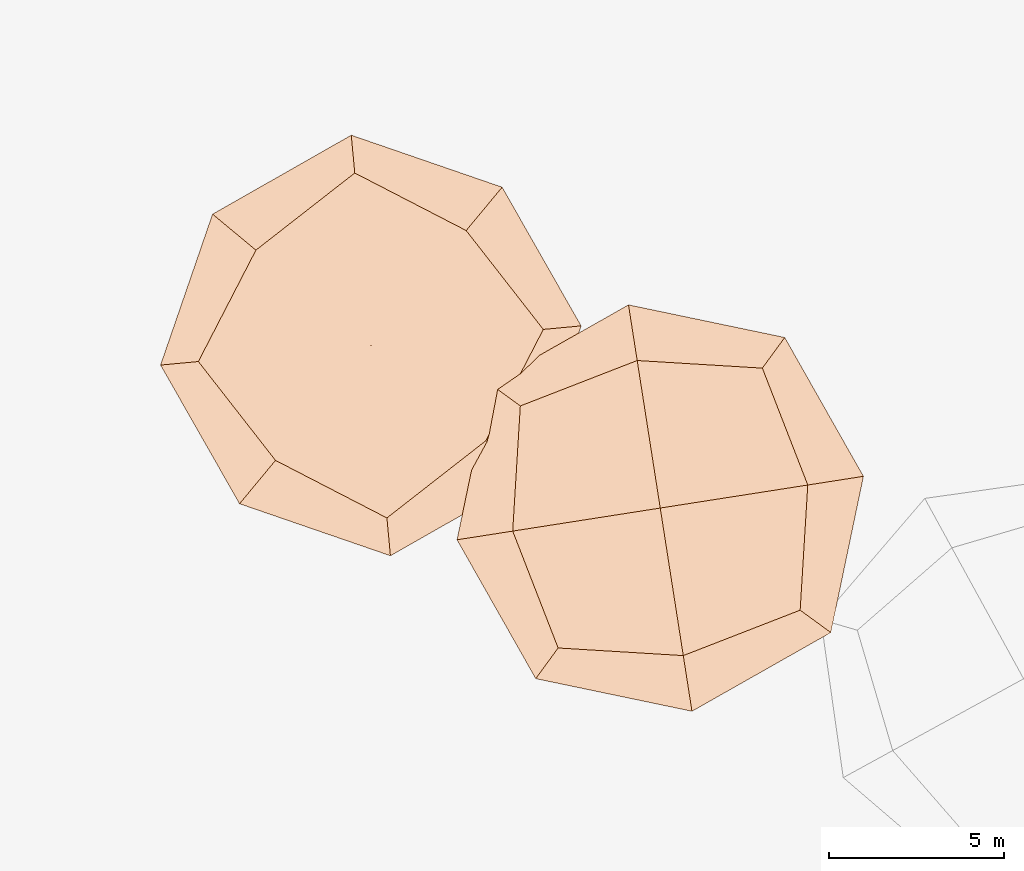
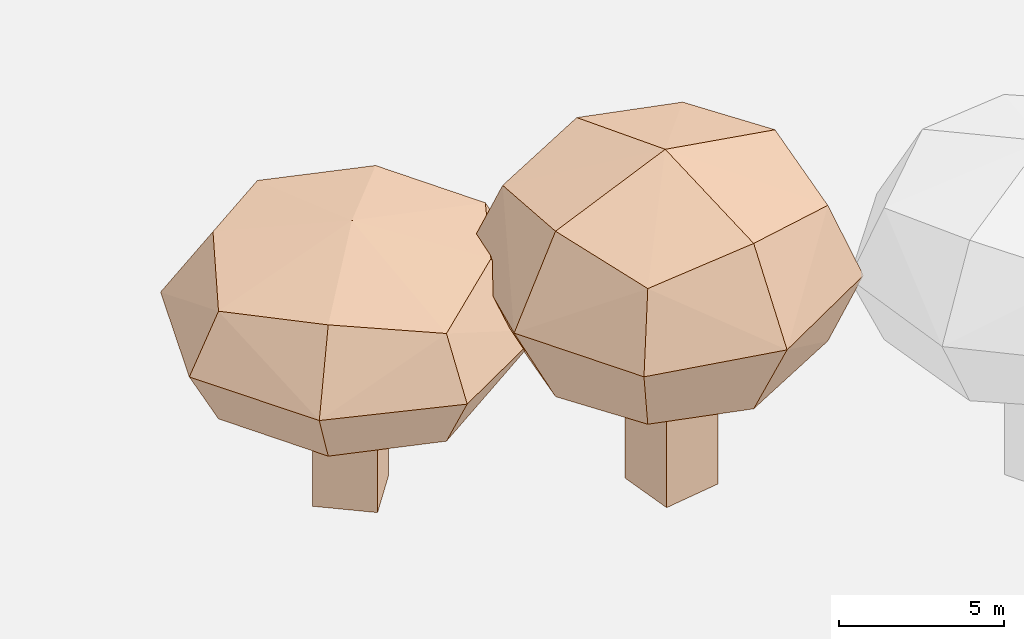
# Not in any storey, part 25 of 92: 2 geographic elements.
"""IFC4 model written with IfcOpenShell, lengths in metres."""

import ifcopenshell
import ifcopenshell.guid

model = None  # the IFC model being written
_history = None  # IfcOwnerHistory: only IFC2X3 demands one
_inside = {}  # id of a spatial element -> (the spatial element, [elements in it])
_under = {}  # id of a project, library or spatial element -> (it, [spatial elements below it])
_declared = {}  # id of a project -> (the project, [libraries it declares])
_typed = {}  # id of a type object -> (the type object, [elements of that type])
_made_of = {}  # id of a material, layer set ... -> (it, [elements and type objects made of it])


def new_model(schema):
    """Start an empty IFC model of exactly this schema.

    Asked for "IFC4X3", IfcOpenShell would pick the latest addendum, in which some entities
    have other attributes; the version numbers below select the first issue.
    IFC2X3 requires an IfcOwnerHistory on every rooted entity: one is made here for all.
    """
    global model, _history
    if schema == "IFC4X3":
        model = ifcopenshell.file(schema_version=(4, 3, 0, 0))
    else:
        model = ifcopenshell.file(schema=schema)
    _inside.clear()
    _under.clear()
    _declared.clear()
    _typed.clear()
    _made_of.clear()
    _history = None
    if model.schema == "IFC2X3":
        org = make("IfcOrganization", Name="unknown")
        user = make(
            "IfcPersonAndOrganization",
            ThePerson=make("IfcPerson", FamilyName="unknown"),
            TheOrganization=org,
        )
        app = make(
            "IfcApplication",
            ApplicationDeveloper=org,
            Version="unknown",
            ApplicationFullName="unknown",
            ApplicationIdentifier="unknown",
        )
        _history = make(
            "IfcOwnerHistory",
            OwningUser=user,
            OwningApplication=app,
            ChangeAction="ADDED",
            CreationDate=0,
        )
    return model


def make(cls, **values):
    """One entity of the class cls with the attributes given. An attribute that is None is left unset."""
    return model.create_entity(
        cls, **{name: value for name, value in values.items() if value is not None}
    )


def rooted(cls, **values):
    """An entity with a GlobalId (a new one), such as an element, a storey or a relation."""
    return make(cls, GlobalId=ifcopenshell.guid.new(), OwnerHistory=_history, **values)


def si_unit(unit_type, name, prefix=None):
    """IfcSIUnit, for example si_unit("LENGTHUNIT", "METRE", prefix="MILLI")."""
    return make("IfcSIUnit", UnitType=unit_type, Prefix=prefix, Name=name)


def assignment(units):
    """IfcUnitAssignment: the units of a project."""
    return None if units is None else make("IfcUnitAssignment", Units=units)


def point(xyz):
    """IfcCartesianPoint."""
    return None if xyz is None else make("IfcCartesianPoint", Coordinates=xyz)


def direction(xyz):
    """IfcDirection."""
    return None if xyz is None else make("IfcDirection", DirectionRatios=xyz)


def frame(location, z_axis=None, x_axis=None):
    """IfcAxis2Placement3D, a coordinate frame: its origin and axes. An axis left out is left unset."""
    return make(
        "IfcAxis2Placement3D",
        Location=point(location),
        Axis=direction(z_axis),
        RefDirection=direction(x_axis),
    )


def origin_with_axes():
    """The frame at (0, 0, 0) with the z axis (0, 0, 1) and the x axis (1, 0, 0) written out."""
    return frame((0.0, 0.0, 0.0), z_axis=(0.0, 0.0, 1.0), x_axis=(1.0, 0.0, 0.0))


def place(relative_to, where):
    """IfcLocalPlacement: puts the frame where relative to a parent placement (None: the world)."""
    return make(
        "IfcLocalPlacement", PlacementRelTo=relative_to, RelativePlacement=where
    )


def context(
    kind, dimensions, precision=None, world=None, true_north=None, identifier=None
):
    """IfcGeometricRepresentationContext, for example the 3D "Model" context."""
    return make(
        "IfcGeometricRepresentationContext",
        ContextIdentifier=identifier,
        ContextType=kind,
        CoordinateSpaceDimension=dimensions,
        Precision=precision,
        WorldCoordinateSystem=world,
        TrueNorth=true_north,
    )


def subcontext(parent, identifier, kind, view, scale=None):
    """IfcGeometricRepresentationSubContext, for example "Body" below "Model"."""
    return make(
        "IfcGeometricRepresentationSubContext",
        ContextIdentifier=identifier,
        ContextType=kind,
        ParentContext=parent,
        TargetScale=scale,
        TargetView=view,
    )


def project(units=None, contexts=None):
    """IfcProject with its units and contexts."""
    return rooted(
        "IfcProject",
        Name="project",
        RepresentationContexts=contexts,
        UnitsInContext=assignment(units),
    )


def spatial(cls, under=None, at=None, **own):
    """A site, building, storey or space (cls), placed at a placement, below another one or the project."""
    s = rooted(cls, ObjectPlacement=at, **own)
    if under is not None:
        _under.setdefault(under.id(), (under, []))[1].append(s)
    return s


def point_list(points):
    """IfcCartesianPointList2D or 3D."""
    cls = (
        "IfcCartesianPointList2D" if len(points[0]) == 2 else "IfcCartesianPointList3D"
    )
    return make(cls, CoordList=points)


def triangles(points, corners, closed=None, point_numbers=None):
    """IfcTriangulatedFaceSet: each triangle names its three corners, points numbered from 1."""
    return make(
        "IfcTriangulatedFaceSet",
        Coordinates=point_list(points),
        Closed=closed,
        CoordIndex=corners,
        PnIndex=point_numbers,
    )


def shape(context_of_items, identifier, shape_type, items):
    """IfcShapeRepresentation: the items that make up one representation, for example the "Body"."""
    return make(
        "IfcShapeRepresentation",
        ContextOfItems=context_of_items,
        RepresentationIdentifier=identifier,
        RepresentationType=shape_type,
        Items=items,
    )


def material(Name=None, Category=None):
    """IfcMaterial."""
    return make("IfcMaterial", Name=Name, Category=Category)


def made_of(thing, what):
    """Note that an element or type object is made of a material, layer set ...; save() writes the relation."""
    if what is not None:
        _made_of.setdefault(what.id(), (what, []))[1].append(thing)
    return thing


def element(
    cls,
    number,
    at=None,
    inside=None,
    cuts=None,
    type_object=None,
    material=None,
    context=None,
    identifier="Body",
    shape_type=None,
    held_by="IfcProductDefinitionShape",
    body=None,
    shapes=None,
    **own,
):
    """One element of the class cls, such as IfcWall. Its Tag is "e" and its number.

    at: its placement. inside: the storey or other place that contains it. cuts: it is an
    opening in that element (IfcRelVoidsElement). A single representation is given by context,
    identifier, shape_type and body (its items); several are given by shapes. held_by: the class
    of the entity that holds the representations. save() writes the other relations.
    """
    e = rooted(cls, Tag="e%d" % number, ObjectPlacement=at, **own)
    if body is not None:
        shapes = [shape(context, identifier, shape_type, body)]
    if shapes is not None:
        e.Representation = make(held_by, Representations=shapes)
    if inside is not None:
        _inside.setdefault(inside.id(), (inside, []))[1].append(e)
    if cuts is not None:
        rooted(
            "IfcRelVoidsElement", RelatingBuildingElement=cuts, RelatedOpeningElement=e
        )
    if type_object is not None:
        _typed.setdefault(type_object.id(), (type_object, []))[1].append(e)
    return made_of(e, material)


def aggregate(whole, parts):
    """IfcRelAggregates: a whole, such as a stair, and the parts it consists of."""
    return rooted("IfcRelAggregates", RelatingObject=whole, RelatedObjects=parts)


def save(model, path):
    """Write the relations noted so far, then the file.

    IfcRelAggregates (storeys below a building ...), IfcRelContainedInSpatialStructure (elements
    in a storey), IfcRelDefinesByType, IfcRelAssociatesMaterial and IfcRelDeclares: one each for
    every whole, place, type object, material and project.
    """
    for whole, parts in _under.values():
        aggregate(whole, parts)
    for where, things in _inside.values():
        rooted(
            "IfcRelContainedInSpatialStructure",
            RelatedElements=things,
            RelatingStructure=where,
        )
    for kind, things in _typed.values():
        rooted("IfcRelDefinesByType", RelatedObjects=things, RelatingType=kind)
    for what, things in _made_of.values():
        rooted("IfcRelAssociatesMaterial", RelatedObjects=things, RelatingMaterial=what)
    for by, libraries in _declared.values():
        rooted("IfcRelDeclares", RelatingContext=by, RelatedDefinitions=libraries)
    model.write(path)


model = new_model("IFC4")

# Units and contexts
model_context = context("Model", 3, precision=1e-05, world=origin_with_axes())
body_context = subcontext(model_context, "Body", "Model", "MODEL_VIEW")
ifc_project = project(units=[si_unit("VOLUMEUNIT", "CUBIC_METRE"), si_unit("LENGTHUNIT", "METRE"), si_unit("AREAUNIT", "SQUARE_METRE")], contexts=[model_context])

# Site
site_placement = place(None, origin_with_axes())
site = spatial("IfcSite", under=ifc_project, at=site_placement)

# Geographic elements
ifc_material = material(Name="tree")
geographic_element_1_placement = place(site_placement, origin_with_axes())
element("IfcGeographicElement", 1, at=geographic_element_1_placement, inside=site, material=ifc_material, Name="cw_instances_tree_183", context=body_context, shape_type="Tessellation", body=[
    triangles([(311.28437798739526, -440.2813640980831, 5.684754447422769), (311.28437798739526, -440.2813640980831, 5.684754447422769), (311.28437798739526, -440.2813640980831, 5.684754447422769), (311.28437798739526, -440.2813640980831, 0.0), (311.28437798739526, -440.2813640980831, 0.0), (311.28437798739526, -440.2813640980831, 0.0), (309.74508674336187, -439.0044214736704, 5.684754447422769), (309.74508674336187, -439.0044214736704, 5.684754447422769), (309.74508674336187, -439.0044214736704, 5.684754447422769), (309.74508674336187, -439.0044214736704, 0.0), (309.74508674336187, -439.0044214736704, 0.0), (309.74508674336187, -439.0044214736704, 0.0), (312.56132061180796, -438.74207285404964, 5.684754447422769), (312.56132061180796, -438.74207285404964, 5.684754447422769), (312.56132061180796, -438.74207285404964, 5.684754447422769), (312.56132061180796, -438.74207285404964, 0.0), (312.56132061180796, -438.74207285404964, 0.0), (312.56132061180796, -438.74207285404964, 0.0), (311.0220293677745, -437.465130229637, 5.684754447422769), (311.0220293677745, -437.465130229637, 5.684754447422769), (311.0220293677745, -437.465130229637, 5.684754447422769), (311.0220293677745, -437.465130229637, 0.0), (311.0220293677745, -437.465130229637, 0.0), (311.0220293677745, -437.465130229637, 0.0), (311.77113207748323, -443.61020842504354, 8.4678125339859), (311.77113207748323, -443.61020842504354, 8.4678125339859), (311.77113207748323, -443.61020842504354, 8.4678125339859), (311.77113207748323, -443.61020842504354, 8.4678125339859), (311.77113207748323, -443.61020842504354, 8.4678125339859), (311.77113207748323, -443.61020842504354, 8.4678125339859), (311.77113229368007, -443.6102089162247, 4.488484579963095), (311.77113229368007, -443.6102089162247, 4.488484579963095), (311.77113229368007, -443.6102089162247, 4.488484579963095), (311.77113229368007, -443.6102089162247, 4.488484579963095), (311.77113229368007, -443.6102089162247, 4.488484579963095), (311.77113229368007, -443.6102089162247, 4.488484579963095), (306.3836138554413, -439.1409104905611, 8.4678125339859), (306.3836138554413, -439.1409104905611, 8.4678125339859), (306.3836138554413, -439.1409104905611, 8.4678125339859), (306.3836138554413, -439.1409104905611, 8.4678125339859), (306.3836138554413, -439.1409104905611, 8.4678125339859), (306.3836138554413, -439.1409104905611, 8.4678125339859), (306.3836138554413, -439.1409104905611, 4.488484579963095), (306.3836138554413, -439.1409104905611, 4.488484579963095), (306.3836138554413, -439.1409104905611, 4.488484579963095), (306.3836138554413, -439.1409104905611, 4.488484579963095), (306.3836138554413, -439.1409104905611, 4.488484579963095), (306.3836138554413, -439.1409104905611, 4.488484579963095), (316.24043117904296, -438.2226899238411, 8.4678125339859), (316.24043117904296, -438.2226899238411, 8.4678125339859), (316.24043117904296, -438.2226899238411, 8.4678125339859), (316.24043117904296, -438.2226899238411, 8.4678125339859), (316.24043117904296, -438.2226899238411, 8.4678125339859), (316.24043117904296, -438.2226899238411, 8.4678125339859), (316.2404308725767, -438.222690293271, 4.488484579963095), (316.2404308725767, -438.222690293271, 4.488484579963095), (316.2404308725767, -438.222690293271, 4.488484579963095), (316.2404308725767, -438.222690293271, 4.488484579963095), (316.2404308725767, -438.222690293271, 4.488484579963095), (316.2404308725767, -438.222690293271, 4.488484579963095), (310.8529125560892, -433.7533913449444, 8.4678125339859), (310.8529125560892, -433.7533913449444, 8.4678125339859), (310.8529125560892, -433.7533913449444, 8.4678125339859), (310.8529125560892, -433.7533913449444, 8.4678125339859), (310.8529125560892, -433.7533913449444, 8.4678125339859), (310.8529125560892, -433.7533913449444, 8.4678125339859), (310.8529127408042, -433.7533914981775, 4.488484579963095), (310.8529127408042, -433.7533914981775, 4.488484579963095), (310.8529127408042, -433.7533914981775, 4.488484579963095), (310.8529127408042, -433.7533914981775, 4.488484579963095), (310.8529127408042, -433.7533914981775, 4.488484579963095), (310.8529127408042, -433.7533914981775, 4.488484579963095), (314.03636333962316, -435.39774173544106, 4.052478611199429), (314.03636333962316, -435.39774173544106, 4.052478611199429), (314.03636333962316, -435.39774173544106, 4.052478611199429), (314.03636333962316, -435.39774173544106, 4.052478611199429), (314.59608042637115, -441.40614078372386, 4.052478611199429), (314.59608042637115, -441.40614078372386, 4.052478611199429), (314.59608042637115, -441.40614078372386, 4.052478611199429), (314.59608042637115, -441.40614078372386, 4.052478611199429), (311.8717398225159, -444.69019878061926, 6.478148898059785), (311.8717398225159, -444.69019878061926, 6.478148898059785), (311.8717398225159, -444.69019878061926, 6.478148898059785), (311.8717398225159, -444.69019878061926, 6.478148898059785), (310.75230532733485, -432.6734011188164, 6.478148898059785), (310.75230532733485, -432.6734011188164, 6.478148898059785), (310.75230532733485, -432.6734011188164, 6.478148898059785), (310.75230532733485, -432.6734011188164, 6.478148898059785), (305.303623113035, -439.2415175898678, 6.478148898059785), (305.303623113035, -439.2415175898678, 6.478148898059785), (305.303623113035, -439.2415175898678, 6.478148898059785), (305.303623113035, -439.2415175898678, 6.478148898059785), (317.3204210685346, -438.1220827406497, 6.478148898059785), (317.3204210685346, -438.1220827406497, 6.478148898059785), (317.3204210685346, -438.1220827406497, 6.478148898059785), (317.3204210685346, -438.1220827406497, 6.478148898059785), (308.0279640169717, -435.95745923123894, 8.903818161664278), (308.0279640169717, -435.95745923123894, 8.903818161664278), (308.0279640169717, -435.95745923123894, 8.903818161664278), (308.0279640169717, -435.95745923123894, 8.903818161664278), (308.5876815640213, -441.96585857042106, 8.903819497581653), (308.5876815640213, -441.96585857042106, 8.903819497581653), (308.5876815640213, -441.96585857042106, 8.903819497581653), (308.5876815640213, -441.96585857042106, 8.903819497581653), (308.0279644106287, -435.95745949283815, 4.052478611199429), (308.0279644106287, -435.95745949283815, 4.052478611199429), (308.0279644106287, -435.95745949283815, 4.052478611199429), (308.0279644106287, -435.95745949283815, 4.052478611199429), (314.036363370409, -435.3977417609799, 8.903818161664278), (314.036363370409, -435.3977417609799, 8.903818161664278), (314.036363370409, -435.3977417609799, 8.903818161664278), (314.036363370409, -435.3977417609799, 8.903818161664278), (314.596080407217, -441.4061408068132, 8.903819497581653), (314.596080407217, -441.4061408068132, 8.903819497581653), (314.596080407217, -441.4061408068132, 8.903819497581653), (314.596080407217, -441.4061408068132, 8.903819497581653), (308.5876818179241, -441.9658581703793, 4.052478611199429), (308.5876818179241, -441.9658581703793, 4.052478611199429), (308.5876818179241, -441.9658581703793, 4.052478611199429), (308.5876818179241, -441.9658581703793, 4.052478611199429), (311.3120225729109, -438.68180019491354, 9.818819778209875), (311.3120225729109, -438.68180019491354, 9.818819778209875), (311.3120225729109, -438.68180019491354, 9.818819778209875), (311.3120225729109, -438.68180019491354, 9.818819778209875), (311.3120225729109, -438.68180019491354, 9.818819778209875), (311.3120225729109, -438.68180019491354, 9.818819778209875), (311.3120225729109, -438.68180019491354, 9.818819778209875), (311.3120225729109, -438.68180019491354, 9.818819778209875), (306.7891673295059, -434.92979646804326, 6.478148898059785), (306.7891673295059, -434.92979646804326, 6.478148898059785), (306.7891673295059, -434.92979646804326, 6.478148898059785), (306.7891673295059, -434.92979646804326, 6.478148898059785), (306.7891673295059, -434.92979646804326, 6.478148898059785), (306.7891673295059, -434.92979646804326, 6.478148898059785), (306.7891673295059, -434.92979646804326, 6.478148898059785), (306.7891673295059, -434.92979646804326, 6.478148898059785), (315.0640261259082, -434.1589450671294, 6.478148898059785), (315.0640261259082, -434.1589450671294, 6.478148898059785), (315.0640261259082, -434.1589450671294, 6.478148898059785), (315.0640261259082, -434.1589450671294, 6.478148898059785), (315.0640261259082, -434.1589450671294, 6.478148898059785), (315.0640261259082, -434.1589450671294, 6.478148898059785), (315.0640261259082, -434.1589450671294, 6.478148898059785), (315.0640261259082, -434.1589450671294, 6.478148898059785), (311.3120224835249, -438.68180030266393, 3.1374786716564955), (311.3120224835249, -438.68180030266393, 3.1374786716564955), (311.3120224835249, -438.68180030266393, 3.1374786716564955), (311.3120224835249, -438.68180030266393, 3.1374786716564955), (311.3120224835249, -438.68180030266393, 3.1374786716564955), (311.3120224835249, -438.68180030266393, 3.1374786716564955), (311.3120224835249, -438.68180030266393, 3.1374786716564955), (311.3120224835249, -438.68180030266393, 3.1374786716564955), (307.56001915478237, -443.20465494084635, 6.478148898059785), (307.56001915478237, -443.20465494084635, 6.478148898059785), (307.56001915478237, -443.20465494084635, 6.478148898059785), (307.56001915478237, -443.20465494084635, 6.478148898059785), (307.56001915478237, -443.20465494084635, 6.478148898059785), (307.56001915478237, -443.20465494084635, 6.478148898059785), (307.56001915478237, -443.20465494084635, 6.478148898059785), (307.56001915478237, -443.20465494084635, 6.478148898059785), (315.8348775151904, -442.43380381490346, 6.478148898059785), (315.8348775151904, -442.43380381490346, 6.478148898059785), (315.8348775151904, -442.43380381490346, 6.478148898059785), (315.8348775151904, -442.43380381490346, 6.478148898059785), (315.8348775151904, -442.43380381490346, 6.478148898059785), (315.8348775151904, -442.43380381490346, 6.478148898059785), (315.8348775151904, -442.43380381490346, 6.478148898059785), (315.8348775151904, -442.43380381490346, 6.478148898059785)], [[15, 8, 2], [7, 24, 11], [19, 16, 22], [4, 23, 17], [3, 12, 6], [14, 5, 18], [26, 127, 101], [54, 123, 114], [124, 66, 98], [128, 38, 102], [45, 133, 108], [40, 135, 89], [130, 63, 88], [131, 70, 105], [68, 141, 73], [61, 140, 86], [137, 49, 93], [142, 56, 74], [59, 145, 75], [31, 149, 79], [150, 43, 107], [146, 71, 76], [35, 154, 120], [30, 157, 83], [158, 42, 91], [153, 47, 119], [58, 164, 77], [51, 162, 96], [167, 28, 81], [165, 33, 80], [15, 21, 8], [7, 20, 24], [19, 13, 16], [4, 10, 23], [3, 9, 12], [14, 1, 5], [25, 115, 126], [53, 111, 121], [122, 112, 65], [125, 99, 37], [46, 90, 136], [39, 100, 134], [132, 97, 64], [129, 87, 69], [67, 85, 138], [62, 110, 144], [143, 109, 50], [139, 94, 55], [60, 78, 147], [32, 117, 151], [152, 118, 44], [148, 106, 72], [36, 84, 160], [29, 104, 156], [155, 103, 41], [159, 92, 48], [57, 95, 161], [52, 113, 163], [166, 116, 27], [168, 82, 34]], closed=True),
])
geographic_element_2_placement = place(site_placement, origin_with_axes())
element("IfcGeographicElement", 2, at=geographic_element_2_placement, inside=site, material=ifc_material, Name="cw_instances_tree_184", context=body_context, shape_type="Tessellation", body=[
    triangles([(320.6611011553659, -442.1469222384115, 7.161511177002393), (320.6611011553659, -442.1469222384115, 7.161511177002393), (320.6611011553659, -442.1469222384115, 7.161511177002393), (320.6611011553659, -442.1469222384115, 0.0), (320.6611011553659, -442.1469222384115, 0.0), (320.6611011553659, -442.1469222384115, 0.0), (320.96973533436073, -444.1229649868246, 7.161511177002393), (320.96973533436073, -444.1229649868246, 7.161511177002393), (320.96973533436073, -444.1229649868246, 7.161511177002393), (320.96973533436073, -444.1229649868246, 0.0), (320.96973533436073, -444.1229649868246, 0.0), (320.96973533436073, -444.1229649868246, 0.0), (318.68505840695275, -442.45555641740634, 7.161511177002393), (318.68505840695275, -442.45555641740634, 7.161511177002393), (318.68505840695275, -442.45555641740634, 7.161511177002393), (318.68505840695275, -442.45555641740634, 0.0), (318.68505840695275, -442.45555641740634, 0.0), (318.68505840695275, -442.45555641740634, 0.0), (318.9936925859476, -444.4315991658195, 7.161511177002393), (318.9936925859476, -444.4315991658195, 7.161511177002393), (318.9936925859476, -444.4315991658195, 7.161511177002393), (318.9936925859476, -444.4315991658195, 0.0), (318.9936925859476, -444.4315991658195, 0.0), (318.9936925859476, -444.4315991658195, 0.0), (322.4995935041025, -439.32946239291397, 10.66753800322786), (322.4995935041025, -439.32946239291397, 10.66753800322786), (322.4995935041025, -439.32946239291397, 10.66753800322786), (322.4995935041025, -439.32946239291397, 10.66753800322786), (322.4995935041025, -439.32946239291397, 10.66753800322786), (322.4995935041025, -439.32946239291397, 10.66753800322786), (322.4995936671554, -439.32946188162765, 5.654480379848509), (322.4995936671554, -439.32946188162765, 5.654480379848509), (322.4995936671554, -439.32946188162765, 5.654480379848509), (322.4995936671554, -439.32946188162765, 5.654480379848509), (322.4995936671554, -439.32946188162765, 5.654480379848509), (322.4995936671554, -439.32946188162765, 5.654480379848509), (323.57981311, -446.2456103253282, 10.66753800322786), (323.57981311, -446.2456103253282, 10.66753800322786), (323.57981311, -446.2456103253282, 10.66753800322786), (323.57981311, -446.2456103253282, 10.66753800322786), (323.57981311, -446.2456103253282, 10.66753800322786), (323.57981311, -446.2456103253282, 10.66753800322786), (323.57981311, -446.2456103253282, 5.654480379848509), (323.57981311, -446.2456103253282, 5.654480379848509), (323.57981311, -446.2456103253282, 5.654480379848509), (323.57981311, -446.2456103253282, 5.654480379848509), (323.57981311, -446.2456103253282, 5.654480379848509), (323.57981311, -446.2456103253282, 5.654480379848509), (315.58344451207944, -440.4096814355805, 10.66753800322786), (315.58344451207944, -440.4096814355805, 10.66753800322786), (315.58344451207944, -440.4096814355805, 10.66753800322786), (315.58344451207944, -440.4096814355805, 10.66753800322786), (315.58344451207944, -440.4096814355805, 10.66753800322786), (315.58344451207944, -440.4096814355805, 10.66753800322786), (315.5834449863297, -440.4096813615083, 5.654480379848509), (315.5834449863297, -440.4096813615083, 5.654480379848509), (315.5834449863297, -440.4096813615083, 5.654480379848509), (315.5834449863297, -440.4096813615083, 5.654480379848509), (315.5834449863297, -440.4096813615083, 5.654480379848509), (315.5834449863297, -440.4096813615083, 5.654480379848509), (316.6636639919601, -447.3258301164062, 10.66753800322786), (316.6636639919601, -447.3258301164062, 10.66753800322786), (316.6636639919601, -447.3258301164062, 10.66753800322786), (316.6636639919601, -447.3258301164062, 10.66753800322786), (316.6636639919601, -447.3258301164062, 10.66753800322786), (316.6636639919601, -447.3258301164062, 10.66753800322786), (316.663663954924, -447.32582987928106, 5.654480379848509), (316.663663954924, -447.32582987928106, 5.654480379848509), (316.663663954924, -447.32582987928106, 5.654480379848509), (316.663663954924, -447.32582987928106, 5.654480379848509), (316.663663954924, -447.32582987928106, 5.654480379848509), (316.663663954924, -447.32582987928106, 5.654480379848509), (315.36576663989416, -443.9861131281856, 5.10521098793021), (315.36576663989416, -443.9861131281856, 5.10521098793021), (315.36576663989416, -443.9861131281856, 5.10521098793021), (315.36576663989416, -443.9861131281856, 5.10521098793021), (318.9231618223192, -439.1117842660075, 5.10521098793021), (318.9231618223192, -439.1117842660075, 5.10521098793021), (318.9231618223192, -439.1117842660075, 5.10521098793021), (318.9231618223192, -439.1117842660075, 5.10521098793021), (323.13902351534676, -438.4533172295893, 8.161009621228882), (323.13902351534676, -438.4533172295893, 8.161009621228882), (323.13902351534676, -438.4533172295893, 8.161009621228882), (323.13902351534676, -438.4533172295893, 8.161009621228882), (316.0242336793987, -448.2019748409736, 8.161009621228882), (316.0242336793987, -448.2019748409736, 8.161009621228882), (316.0242336793987, -448.2019748409736, 8.161009621228882), (316.0242336793987, -448.2019748409736, 8.161009621228882), (324.4559581358845, -446.8850410766469, 8.161009621228882), (324.4559581358845, -446.8850410766469, 8.161009621228882), (324.4559581358845, -446.8850410766469, 8.161009621228882), (324.4559581358845, -446.8850410766469, 8.161009621228882), (314.7073000700103, -439.7702513116847, 8.161009621228882), (314.7073000700103, -439.7702513116847, 8.161009621228882), (314.7073000700103, -439.7702513116847, 8.161009621228882), (314.7073000700103, -439.7702513116847, 8.161009621228882), (320.24009597848686, -447.5435081855942, 11.216806965455461), (320.24009597848686, -447.5435081855942, 11.216806965455461), (320.24009597848686, -447.5435081855942, 11.216806965455461), (320.24009597848686, -447.5435081855942, 11.216806965455461), (323.7974910084192, -442.6691788006868, 11.216808648410689), (323.7974910084192, -442.6691788006868, 11.216808648410689), (323.7974910084192, -442.6691788006868, 11.216808648410689), (323.7974910084192, -442.6691788006868, 11.216808648410689), (320.24009585655676, -447.54350772893997, 5.10521098793021), (320.24009585655676, -447.54350772893997, 5.10521098793021), (320.24009585655676, -447.54350772893997, 5.10521098793021), (320.24009585655676, -447.54350772893997, 5.10521098793021), (315.3657666337215, -443.98611308866475, 11.216806965455461), (315.3657666337215, -443.98611308866475, 11.216806965455461), (315.3657666337215, -443.98611308866475, 11.216806965455461), (315.3657666337215, -443.98611308866475, 11.216806965455461), (318.92316185195983, -439.111784261378, 11.216808648410689), (318.92316185195983, -439.111784261378, 11.216808648410689), (318.92316185195983, -439.111784261378, 11.216808648410689), (318.92316185195983, -439.111784261378, 11.216808648410689), (323.79749055330814, -442.66917893249706, 5.10521098793021), (323.79749055330814, -442.66917893249706, 5.10521098793021), (323.79749055330814, -442.66917893249706, 5.10521098793021), (323.79749055330814, -442.66917893249706, 5.10521098793021), (319.5816287611776, -443.32764585281785, 12.369503069477563), (319.5816287611776, -443.32764585281785, 12.369503069477563), (319.5816287611776, -443.32764585281785, 12.369503069477563), (319.5816287611776, -443.32764585281785, 12.369503069477563), (319.5816287611776, -443.32764585281785, 12.369503069477563), (319.5816287611776, -443.32764585281785, 12.369503069477563), (319.5816287611776, -443.32764585281785, 12.369503069477563), (319.5816287611776, -443.32764585281785, 12.369503069477563), (320.4884797720409, -449.1337954171454, 8.161009621228882), (320.4884797720409, -449.1337954171454, 8.161009621228882), (320.4884797720409, -449.1337954171454, 8.161009621228882), (320.4884797720409, -449.1337954171454, 8.161009621228882), (320.4884797720409, -449.1337954171454, 8.161009621228882), (320.4884797720409, -449.1337954171454, 8.161009621228882), (320.4884797720409, -449.1337954171454, 8.161009621228882), (320.4884797720409, -449.1337954171454, 8.161009621228882), (313.7754794037134, -444.23449689209895, 8.161009621228882), (313.7754794037134, -444.23449689209895, 8.161009621228882), (313.7754794037134, -444.23449689209895, 8.161009621228882), (313.7754794037134, -444.23449689209895, 8.161009621228882), (313.7754794037134, -444.23449689209895, 8.161009621228882), (313.7754794037134, -444.23449689209895, 8.161009621228882), (313.7754794037134, -444.23449689209895, 8.161009621228882), (313.7754794037134, -444.23449689209895, 8.161009621228882), (319.58162889950063, -443.3276458312135, 3.9525169965540314), (319.58162889950063, -443.3276458312135, 3.9525169965540314), (319.58162889950063, -443.3276458312135, 3.9525169965540314), (319.58162889950063, -443.3276458312135, 3.9525169965540314), (319.58162889950063, -443.3276458312135, 3.9525169965540314), (319.58162889950063, -443.3276458312135, 3.9525169965540314), (319.58162889950063, -443.3276458312135, 3.9525169965540314), (319.58162889950063, -443.3276458312135, 3.9525169965540314), (325.38777776479816, -442.4207950105003, 8.161009621228882), (325.38777776479816, -442.4207950105003, 8.161009621228882), (325.38777776479816, -442.4207950105003, 8.161009621228882), (325.38777776479816, -442.4207950105003, 8.161009621228882), (325.38777776479816, -442.4207950105003, 8.161009621228882), (325.38777776479816, -442.4207950105003, 8.161009621228882), (325.38777776479816, -442.4207950105003, 8.161009621228882), (325.38777776479816, -442.4207950105003, 8.161009621228882), (318.6747779052919, -437.5214965679219, 8.161009621228882), (318.6747779052919, -437.5214965679219, 8.161009621228882), (318.6747779052919, -437.5214965679219, 8.161009621228882), (318.6747779052919, -437.5214965679219, 8.161009621228882), (318.6747779052919, -437.5214965679219, 8.161009621228882), (318.6747779052919, -437.5214965679219, 8.161009621228882), (318.6747779052919, -437.5214965679219, 8.161009621228882), (318.6747779052919, -437.5214965679219, 8.161009621228882)], [[15, 8, 2], [7, 24, 11], [19, 16, 22], [4, 23, 17], [3, 12, 6], [14, 5, 18], [26, 127, 101], [54, 123, 114], [124, 66, 98], [128, 38, 102], [45, 133, 108], [40, 135, 89], [130, 63, 88], [131, 70, 105], [68, 141, 73], [61, 140, 86], [137, 49, 93], [142, 56, 74], [59, 145, 75], [31, 149, 79], [150, 43, 107], [146, 71, 76], [35, 154, 120], [30, 157, 83], [158, 42, 91], [153, 47, 119], [58, 164, 77], [51, 162, 96], [167, 28, 81], [165, 33, 80], [15, 21, 8], [7, 20, 24], [19, 13, 16], [4, 10, 23], [3, 9, 12], [14, 1, 5], [25, 115, 126], [53, 111, 121], [122, 112, 65], [125, 99, 37], [46, 90, 136], [39, 100, 134], [132, 97, 64], [129, 87, 69], [67, 85, 138], [62, 110, 144], [143, 109, 50], [139, 94, 55], [60, 78, 147], [32, 117, 151], [152, 118, 44], [148, 106, 72], [36, 84, 160], [29, 104, 156], [155, 103, 41], [159, 92, 48], [57, 95, 161], [52, 113, 163], [166, 116, 27], [168, 82, 34]], closed=True),
])

save(model, "model.ifc")
